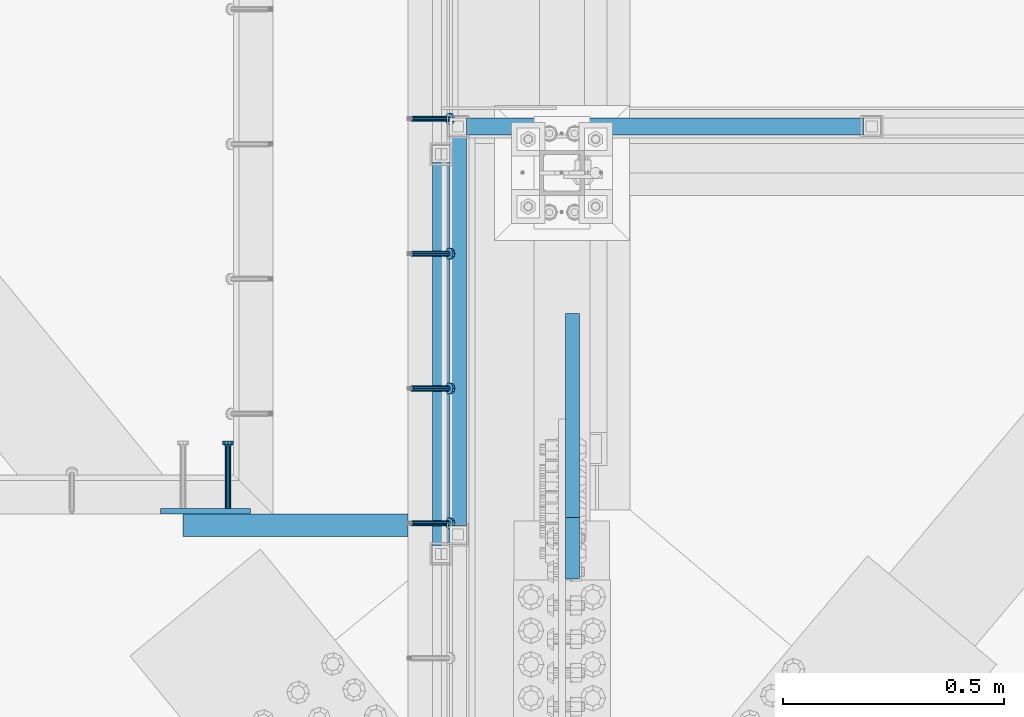
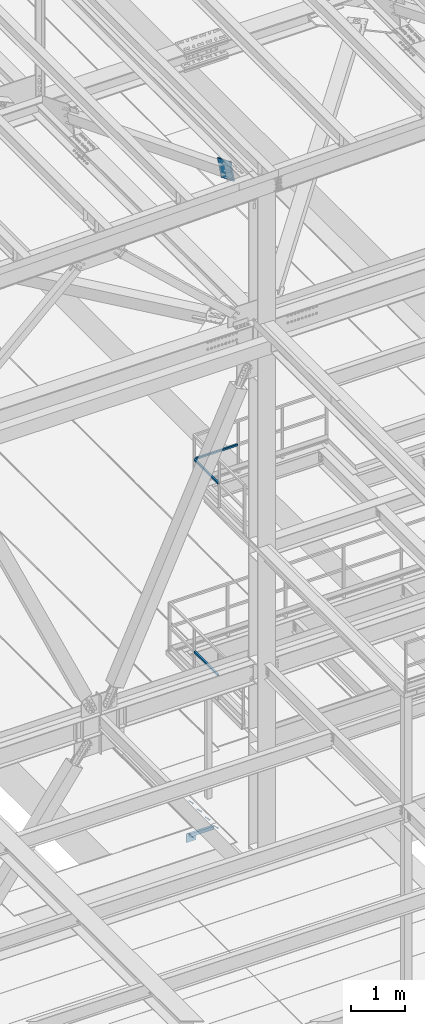
# One storey, part 2111 of 3843: 6 beams, 5 members, 6 elements without a shape of their own.
"""IFC2X3 building model written with IfcOpenShell, lengths in millimetres."""

from ifc_helpers import new_model, si_unit, frame, origin_with_axes, place, context, subcontext, project, spatial, faceted_brep, material, type_object, element, aggregate, save


model = new_model("IFC2X3")

# Units and contexts
model_context = context("Model", 3, precision=1e-05, world=origin_with_axes())
body_context = subcontext(model_context, "Body", "Model", "MODEL_VIEW")
ifc_project = project(units=[si_unit("LENGTHUNIT", "METRE", prefix="MILLI"), si_unit("AREAUNIT", "SQUARE_METRE"), si_unit("VOLUMEUNIT", "CUBIC_METRE"), si_unit("MASSUNIT", "GRAM", prefix="KILO"), si_unit("TIMEUNIT", "SECOND"), si_unit("PLANEANGLEUNIT", "RADIAN"), si_unit("SOLIDANGLEUNIT", "STERADIAN"), si_unit("THERMODYNAMICTEMPERATUREUNIT", "DEGREE_CELSIUS"), si_unit("LUMINOUSINTENSITYUNIT", "LUMEN")], contexts=[model_context])

# Site, building, storey
site_placement = place(None, origin_with_axes())
site = spatial("IfcSite", under=ifc_project, at=site_placement, CompositionType="ELEMENT")
building_placement = place(site_placement, origin_with_axes())
building = spatial("IfcBuilding", under=site, at=building_placement, Name="Undefined", CompositionType="ELEMENT")
storey_placement = place(building_placement, origin_with_axes())
storey = spatial("IfcBuildingStorey", under=building, at=storey_placement, Name="Undefined", CompositionType="ELEMENT", Elevation=0.0)

# Assembly, members
assembly_1_placement = place(storey_placement, origin_with_axes())
assembly_1 = element("IfcElementAssembly", 1, at=assembly_1_placement, inside=storey, Name="EMBED_ANGLE", AssemblyPlace="NOTDEFINED", PredefinedType="RIGID_FRAME")
ifc_material_1 = material(Name="STEEL/A108")
member_type_1 = type_object("IfcMemberType", PredefinedType="NOTDEFINED")
member_1_placement = place(assembly_1_placement, frame((48656.0495, 27719.3375, 30446.6625), z_axis=(0.0, 1.0, 0.0), x_axis=(0.707106781186548, 0.0, -0.707106781186548)))
member_1 = element("IfcMember", 2, at=member_1_placement, type_object=member_type_1, material=ifc_material_1, Name="HEADED STUD ANCHOR", context=body_context, shape_type="Brep", body=[
    faceted_brep([(7.27595761418343e-12, -3.18000006675175, 5.5), (0.0, -5.49999999998363, 3.1800000667572), (118.110000000976, -5.49999999999091, 3.1800000667572), (118.110000000983, -3.18000006675175, 5.5), (0.0, -6.3499999046162, 0.0), (118.110000000968, -6.34999990461256, 0.0), (0.0, -5.49999999998363, -3.1800000667572), (118.110000000976, -5.49999999999091, -3.1800000667572), (7.27595761418343e-12, -3.18000006675175, -5.5), (118.110000000983, -3.18000006675175, -5.5), (7.27595761418343e-12, -1.81898940354586e-12, -6.34999990463257), (118.110000000968, -1.81898940354586e-12, -6.34999990463257), (0.0, 3.18000006675175, -5.5), (118.110000000968, 3.18000006674811, -5.5), (7.27595761418343e-12, 5.49999999998363, -3.1800000667572), (118.110000000983, 5.49999999998363, -3.1800000667572), (7.27595761418343e-12, 6.3499999046162, 0.0), (118.110000000976, 6.34999990461256, 0.0), (7.27595761418343e-12, 5.49999999998363, 3.1800000667572), (118.110000000983, 5.49999999998363, 3.1800000667572), (0.0, 3.18000006675175, 5.5), (118.110000000968, 3.18000006674811, 5.5), (7.27595761418343e-12, -1.81898940354586e-12, 6.34999990463257), (118.110000000968, -1.81898940354586e-12, 6.34999990463257), (120.650000000991, -10.9899997710909, 6.34999990463257), (120.650000000998, -6.34000015257152, 10.9899997711182), (120.650000000991, -12.6999998092379, 0.0), (120.650000000991, -10.9899997710909, -6.34999990463257), (120.650000000998, -6.34000015257152, -10.9899997711182), (120.650000000991, -1.81898940354586e-12, -12.6899995803833), (120.650000000991, 6.34000015257152, -10.9899997711182), (120.650000000998, 10.9899997710909, -6.34999990463257), (120.650000000991, 12.6999998092342, 0.0), (120.650000000998, 10.9899997710909, 6.34999990463257), (120.650000000991, 6.34000015257152, 10.9899997711182), (120.650000000991, -1.81898940354586e-12, 12.6899995803833), (127.000000001048, -10.9899997710945, 6.34999990463257), (127.000000001048, -6.34000015257152, 10.9899997711182), (127.000000001048, -12.6999998092342, 0.0), (127.000000001048, -10.9899997710945, -6.34999990463257), (127.000000001048, -6.34000015257152, -10.9899997711182), (127.000000001048, 1.81898940354586e-12, -12.6899995803833), (127.000000001048, 6.34000015256788, -10.9899997711182), (127.000000001048, 10.9899997710909, -6.34999990463257), (127.000000001048, 12.6999998092379, 0.0), (127.000000001048, 10.9899997710909, 6.34999990463257), (127.000000001048, 6.34000015256788, 10.9899997711182), (127.000000001048, 1.81898940354586e-12, 12.6899995803833)], [[[0, 1, 2, 3]], [[1, 4, 5, 2]], [[4, 6, 7, 5]], [[6, 8, 9, 7]], [[8, 10, 11, 9]], [[10, 12, 13, 11]], [[12, 14, 15, 13]], [[14, 16, 17, 15]], [[16, 18, 19, 17]], [[18, 20, 21, 19]], [[20, 22, 23, 21]], [[22, 0, 3, 23]], [[22, 20, 18, 16, 14, 12, 10, 8, 6, 4, 1, 0]], [[3, 2, 24, 25]], [[2, 5, 26, 24]], [[5, 7, 27, 26]], [[7, 9, 28, 27]], [[9, 11, 29, 28]], [[11, 13, 30, 29]], [[13, 15, 31, 30]], [[15, 17, 32, 31]], [[17, 19, 33, 32]], [[19, 21, 34, 33]], [[21, 23, 35, 34]], [[23, 3, 25, 35]], [[25, 24, 36, 37]], [[24, 26, 38, 36]], [[26, 27, 39, 38]], [[27, 28, 40, 39]], [[28, 29, 41, 40]], [[29, 30, 42, 41]], [[30, 31, 43, 42]], [[31, 32, 44, 43]], [[32, 33, 45, 44]], [[33, 34, 46, 45]], [[34, 35, 47, 46]], [[35, 25, 37, 47]], [[38, 39, 40, 41, 42, 43, 44, 45, 46, 47, 37, 36]]]),
])
member_2_placement = place(assembly_1_placement, frame((48656.0495, 27414.5375, 30446.6625), z_axis=(0.0, 1.0, 0.0), x_axis=(0.707106781186548, 0.0, -0.707106781186548)))
member_2 = element("IfcMember", 3, at=member_2_placement, type_object=member_type_1, material=ifc_material_1, Name="HEADED STUD ANCHOR", context=body_context, shape_type="Brep", body=[
    faceted_brep([(7.27595761418343e-12, -3.18000006675175, 5.5), (0.0, -5.49999999998363, 3.1800000667572), (118.110000000976, -5.49999999999091, 3.1800000667572), (118.110000000983, -3.18000006675175, 5.5), (0.0, -6.3499999046162, 0.0), (118.110000000968, -6.34999990461256, 0.0), (0.0, -5.49999999998363, -3.1800000667572), (118.110000000976, -5.49999999999091, -3.1800000667572), (7.27595761418343e-12, -3.18000006675175, -5.5), (118.110000000983, -3.18000006675175, -5.5), (7.27595761418343e-12, -1.81898940354586e-12, -6.34999990463257), (118.110000000968, -1.81898940354586e-12, -6.34999990463257), (0.0, 3.18000006675175, -5.5), (118.110000000968, 3.18000006674811, -5.5), (7.27595761418343e-12, 5.49999999998363, -3.1800000667572), (118.110000000983, 5.49999999998363, -3.1800000667572), (7.27595761418343e-12, 6.3499999046162, 0.0), (118.110000000976, 6.34999990461256, 0.0), (7.27595761418343e-12, 5.49999999998363, 3.1800000667572), (118.110000000983, 5.49999999998363, 3.1800000667572), (0.0, 3.18000006675175, 5.5), (118.110000000968, 3.18000006674811, 5.5), (7.27595761418343e-12, -1.81898940354586e-12, 6.34999990463257), (118.110000000968, -1.81898940354586e-12, 6.34999990463257), (120.650000000991, -10.9899997710909, 6.34999990463257), (120.650000000998, -6.34000015257152, 10.9899997711182), (120.650000000991, -12.6999998092379, 0.0), (120.650000000991, -10.9899997710909, -6.34999990463257), (120.650000000998, -6.34000015257152, -10.9899997711182), (120.650000000991, -1.81898940354586e-12, -12.6899995803833), (120.650000000991, 6.34000015257152, -10.9899997711182), (120.650000000998, 10.9899997710909, -6.34999990463257), (120.650000000991, 12.6999998092342, 0.0), (120.650000000998, 10.9899997710909, 6.34999990463257), (120.650000000991, 6.34000015257152, 10.9899997711182), (120.650000000991, -1.81898940354586e-12, 12.6899995803833), (127.000000001048, -10.9899997710945, 6.34999990463257), (127.000000001048, -6.34000015257152, 10.9899997711182), (127.000000001048, -12.6999998092342, 0.0), (127.000000001048, -10.9899997710945, -6.34999990463257), (127.000000001048, -6.34000015257152, -10.9899997711182), (127.000000001048, 1.81898940354586e-12, -12.6899995803833), (127.000000001048, 6.34000015256788, -10.9899997711182), (127.000000001048, 10.9899997710909, -6.34999990463257), (127.000000001048, 12.6999998092379, 0.0), (127.000000001048, 10.9899997710909, 6.34999990463257), (127.000000001048, 6.34000015256788, 10.9899997711182), (127.000000001048, 1.81898940354586e-12, 12.6899995803833)], [[[0, 1, 2, 3]], [[1, 4, 5, 2]], [[4, 6, 7, 5]], [[6, 8, 9, 7]], [[8, 10, 11, 9]], [[10, 12, 13, 11]], [[12, 14, 15, 13]], [[14, 16, 17, 15]], [[16, 18, 19, 17]], [[18, 20, 21, 19]], [[20, 22, 23, 21]], [[22, 0, 3, 23]], [[22, 20, 18, 16, 14, 12, 10, 8, 6, 4, 1, 0]], [[3, 2, 24, 25]], [[2, 5, 26, 24]], [[5, 7, 27, 26]], [[7, 9, 28, 27]], [[9, 11, 29, 28]], [[11, 13, 30, 29]], [[13, 15, 31, 30]], [[15, 17, 32, 31]], [[17, 19, 33, 32]], [[19, 21, 34, 33]], [[21, 23, 35, 34]], [[23, 3, 25, 35]], [[25, 24, 36, 37]], [[24, 26, 38, 36]], [[26, 27, 39, 38]], [[27, 28, 40, 39]], [[28, 29, 41, 40]], [[29, 30, 42, 41]], [[30, 31, 43, 42]], [[31, 32, 44, 43]], [[32, 33, 45, 44]], [[33, 34, 46, 45]], [[34, 35, 47, 46]], [[35, 25, 37, 47]], [[38, 39, 40, 41, 42, 43, 44, 45, 46, 47, 37, 36]]]),
])
member_3_placement = place(assembly_1_placement, frame((48656.0495, 27109.7375, 30446.6625), z_axis=(0.0, 1.0, 0.0), x_axis=(0.707106781186548, 0.0, -0.707106781186548)))
member_3 = element("IfcMember", 4, at=member_3_placement, type_object=member_type_1, material=ifc_material_1, Name="HEADED STUD ANCHOR", context=body_context, shape_type="Brep", body=[
    faceted_brep([(7.27595761418343e-12, -3.18000006675175, 5.5), (0.0, -5.49999999998363, 3.1800000667572), (118.110000000976, -5.49999999999091, 3.1800000667572), (118.110000000983, -3.18000006675175, 5.5), (0.0, -6.3499999046162, 0.0), (118.110000000968, -6.34999990461256, 0.0), (0.0, -5.49999999998363, -3.1800000667572), (118.110000000976, -5.49999999999091, -3.1800000667572), (7.27595761418343e-12, -3.18000006675175, -5.5), (118.110000000983, -3.18000006675175, -5.5), (7.27595761418343e-12, -1.81898940354586e-12, -6.34999990463257), (118.110000000968, -1.81898940354586e-12, -6.34999990463257), (0.0, 3.18000006675175, -5.5), (118.110000000968, 3.18000006674811, -5.5), (7.27595761418343e-12, 5.49999999998363, -3.1800000667572), (118.110000000983, 5.49999999998363, -3.1800000667572), (7.27595761418343e-12, 6.3499999046162, 0.0), (118.110000000976, 6.34999990461256, 0.0), (7.27595761418343e-12, 5.49999999998363, 3.1800000667572), (118.110000000983, 5.49999999998363, 3.1800000667572), (0.0, 3.18000006675175, 5.5), (118.110000000968, 3.18000006674811, 5.5), (7.27595761418343e-12, -1.81898940354586e-12, 6.34999990463257), (118.110000000968, -1.81898940354586e-12, 6.34999990463257), (120.650000000991, -10.9899997710909, 6.34999990463257), (120.650000000998, -6.34000015257152, 10.9899997711182), (120.650000000991, -12.6999998092379, 0.0), (120.650000000991, -10.9899997710909, -6.34999990463257), (120.650000000998, -6.34000015257152, -10.9899997711182), (120.650000000991, -1.81898940354586e-12, -12.6899995803833), (120.650000000991, 6.34000015257152, -10.9899997711182), (120.650000000998, 10.9899997710909, -6.34999990463257), (120.650000000991, 12.6999998092342, 0.0), (120.650000000998, 10.9899997710909, 6.34999990463257), (120.650000000991, 6.34000015257152, 10.9899997711182), (120.650000000991, -1.81898940354586e-12, 12.6899995803833), (127.000000001048, -10.9899997710945, 6.34999990463257), (127.000000001048, -6.34000015257152, 10.9899997711182), (127.000000001048, -12.6999998092342, 0.0), (127.000000001048, -10.9899997710945, -6.34999990463257), (127.000000001048, -6.34000015257152, -10.9899997711182), (127.000000001048, 1.81898940354586e-12, -12.6899995803833), (127.000000001048, 6.34000015256788, -10.9899997711182), (127.000000001048, 10.9899997710909, -6.34999990463257), (127.000000001048, 12.6999998092379, 0.0), (127.000000001048, 10.9899997710909, 6.34999990463257), (127.000000001048, 6.34000015256788, 10.9899997711182), (127.000000001048, 1.81898940354586e-12, 12.6899995803833)], [[[0, 1, 2, 3]], [[1, 4, 5, 2]], [[4, 6, 7, 5]], [[6, 8, 9, 7]], [[8, 10, 11, 9]], [[10, 12, 13, 11]], [[12, 14, 15, 13]], [[14, 16, 17, 15]], [[16, 18, 19, 17]], [[18, 20, 21, 19]], [[20, 22, 23, 21]], [[22, 0, 3, 23]], [[22, 20, 18, 16, 14, 12, 10, 8, 6, 4, 1, 0]], [[3, 2, 24, 25]], [[2, 5, 26, 24]], [[5, 7, 27, 26]], [[7, 9, 28, 27]], [[9, 11, 29, 28]], [[11, 13, 30, 29]], [[13, 15, 31, 30]], [[15, 17, 32, 31]], [[17, 19, 33, 32]], [[19, 21, 34, 33]], [[21, 23, 35, 34]], [[23, 3, 25, 35]], [[25, 24, 36, 37]], [[24, 26, 38, 36]], [[26, 27, 39, 38]], [[27, 28, 40, 39]], [[28, 29, 41, 40]], [[29, 30, 42, 41]], [[30, 31, 43, 42]], [[31, 32, 44, 43]], [[32, 33, 45, 44]], [[33, 34, 46, 45]], [[34, 35, 47, 46]], [[35, 25, 37, 47]], [[38, 39, 40, 41, 42, 43, 44, 45, 46, 47, 37, 36]]]),
])
member_4_placement = place(assembly_1_placement, frame((48656.0495, 26804.9375, 30446.6625), z_axis=(0.0, 1.0, 0.0), x_axis=(0.707106781186548, 0.0, -0.707106781186548)))
member_4 = element("IfcMember", 5, at=member_4_placement, type_object=member_type_1, material=ifc_material_1, Name="HEADED STUD ANCHOR", context=body_context, shape_type="Brep", body=[
    faceted_brep([(7.27595761418343e-12, -3.18000006675175, 5.5), (0.0, -5.49999999998363, 3.1800000667572), (118.110000000976, -5.49999999999091, 3.1800000667572), (118.110000000983, -3.18000006675175, 5.5), (0.0, -6.3499999046162, 0.0), (118.110000000968, -6.34999990461256, 0.0), (0.0, -5.49999999998363, -3.1800000667572), (118.110000000976, -5.49999999999091, -3.1800000667572), (7.27595761418343e-12, -3.18000006675175, -5.5), (118.110000000983, -3.18000006675175, -5.5), (7.27595761418343e-12, -1.81898940354586e-12, -6.34999990463257), (118.110000000968, -1.81898940354586e-12, -6.34999990463257), (0.0, 3.18000006675175, -5.5), (118.110000000968, 3.18000006674811, -5.5), (7.27595761418343e-12, 5.49999999998363, -3.1800000667572), (118.110000000983, 5.49999999998363, -3.1800000667572), (7.27595761418343e-12, 6.3499999046162, 0.0), (118.110000000976, 6.34999990461256, 0.0), (7.27595761418343e-12, 5.49999999998363, 3.1800000667572), (118.110000000983, 5.49999999998363, 3.1800000667572), (0.0, 3.18000006675175, 5.5), (118.110000000968, 3.18000006674811, 5.5), (7.27595761418343e-12, -1.81898940354586e-12, 6.34999990463257), (118.110000000968, -1.81898940354586e-12, 6.34999990463257), (120.650000000991, -10.9899997710909, 6.34999990463257), (120.650000000998, -6.34000015257152, 10.9899997711182), (120.650000000991, -12.6999998092379, 0.0), (120.650000000991, -10.9899997710909, -6.34999990463257), (120.650000000998, -6.34000015257152, -10.9899997711182), (120.650000000991, -1.81898940354586e-12, -12.6899995803833), (120.650000000991, 6.34000015257152, -10.9899997711182), (120.650000000998, 10.9899997710909, -6.34999990463257), (120.650000000991, 12.6999998092342, 0.0), (120.650000000998, 10.9899997710909, 6.34999990463257), (120.650000000991, 6.34000015257152, 10.9899997711182), (120.650000000991, -1.81898940354586e-12, 12.6899995803833), (127.000000001048, -10.9899997710945, 6.34999990463257), (127.000000001048, -6.34000015257152, 10.9899997711182), (127.000000001048, -12.6999998092342, 0.0), (127.000000001048, -10.9899997710945, -6.34999990463257), (127.000000001048, -6.34000015257152, -10.9899997711182), (127.000000001048, 1.81898940354586e-12, -12.6899995803833), (127.000000001048, 6.34000015256788, -10.9899997711182), (127.000000001048, 10.9899997710909, -6.34999990463257), (127.000000001048, 12.6999998092379, 0.0), (127.000000001048, 10.9899997710909, 6.34999990463257), (127.000000001048, 6.34000015256788, 10.9899997711182), (127.000000001048, 1.81898940354586e-12, 12.6899995803833)], [[[0, 1, 2, 3]], [[1, 4, 5, 2]], [[4, 6, 7, 5]], [[6, 8, 9, 7]], [[8, 10, 11, 9]], [[10, 12, 13, 11]], [[12, 14, 15, 13]], [[14, 16, 17, 15]], [[16, 18, 19, 17]], [[18, 20, 21, 19]], [[20, 22, 23, 21]], [[22, 0, 3, 23]], [[22, 20, 18, 16, 14, 12, 10, 8, 6, 4, 1, 0]], [[3, 2, 24, 25]], [[2, 5, 26, 24]], [[5, 7, 27, 26]], [[7, 9, 28, 27]], [[9, 11, 29, 28]], [[11, 13, 30, 29]], [[13, 15, 31, 30]], [[15, 17, 32, 31]], [[17, 19, 33, 32]], [[19, 21, 34, 33]], [[21, 23, 35, 34]], [[23, 3, 25, 35]], [[25, 24, 36, 37]], [[24, 26, 38, 36]], [[26, 27, 39, 38]], [[27, 28, 40, 39]], [[28, 29, 41, 40]], [[29, 30, 42, 41]], [[30, 31, 43, 42]], [[31, 32, 44, 43]], [[32, 33, 45, 44]], [[33, 34, 46, 45]], [[34, 35, 47, 46]], [[35, 25, 37, 47]], [[38, 39, 40, 41, 42, 43, 44, 45, 46, 47, 37, 36]]]),
])
aggregate(assembly_1, [member_1, member_2, member_3, member_4])

# Assembly, beams
assembly_2_placement = place(storey_placement, origin_with_axes())
assembly_2 = element("IfcElementAssembly", 6, at=assembly_2_placement, inside=storey, Name="RAIL", AssemblyPlace="NOTDEFINED", PredefinedType="RIGID_FRAME")
ifc_material_2 = material()
beam_type_1 = type_object("IfcBeamType", Name="HSS1-1/2X1-1/2X1/4", PredefinedType="NOTDEFINED")
beam_1_placement = place(assembly_2_placement, frame((49697.2166595459, 27701.8747862042, 38099.9999983618), z_axis=(0.0, 0.0, 1.0), x_axis=(-1.0, 0.0, 0.0)))
beam_1 = element("IfcBeam", 7, at=beam_1_placement, type_object=beam_type_1, material=ifc_material_2, Name="RAIL", ObjectType="HSS1-1/2X1-1/2X1/4", context=body_context, shape_type="Brep", body=[
    faceted_brep([(916.516671752906, -19.0500000000029, 19.0499992350015), (916.516671752906, -19.0499992350015, -19.0499992350015), (916.516671752906, 19.0499992350015, -19.0499992350015), (916.516671752906, 19.0499992350015, 19.0499992350015), (916.516671752906, -12.6999993300014, 12.6999993299978), (916.516671752906, 12.6999993300014, 12.6999993299978), (916.516671752906, 12.6999993300014, -12.6999993299978), (916.516671752906, -12.6999993300014, -12.6999993299978), (19.0499992350015, 19.0499992350015, 19.0499992350015), (19.0499992350015, -19.0499992350015, 19.0499992350015), (19.0499992350015, -19.0499992350015, -19.0499992350015), (19.0499992350015, 19.0499992350015, -19.0499992350015), (19.0499992350015, 12.6999993299978, 12.6999993299978), (19.0499992350015, -12.6999993299978, 12.6999993299978), (19.0499992350015, -12.6999993299978, -12.6999993299978), (19.0499992350015, 12.6999993299978, -12.6999993299978)], [[[0, 1, 2, 3], [4, 5, 6, 7]], [[8, 9, 0, 3]], [[10, 11, 2, 1]], [[9, 10, 1, 0]], [[11, 8, 3, 2]], [[10, 9, 8, 11], [12, 13, 14, 15]], [[14, 13, 4, 7]], [[15, 14, 7, 6]], [[12, 15, 6, 5]], [[13, 12, 5, 4]]]),
])
beam_2_placement = place(assembly_2_placement, frame((48761.6499877927, 27701.8747862042, 38099.9999983618), z_axis=(0.0, 0.0, 1.0), x_axis=(0.0, -1.0, 0.0)))
beam_2 = element("IfcBeam", 8, at=beam_2_placement, type_object=beam_type_1, material=ifc_material_2, Name="RAIL", ObjectType="HSS1-1/2X1-1/2X1/4", context=body_context, shape_type="Brep", body=[
    faceted_brep([(903.287393102968, -19.0500000001557, 19.0499992350015), (903.287393102968, -19.0499992350015, -19.0499992350015), (903.287393102968, 19.0499992350015, -19.0499992350015), (903.287393102968, 19.0499992350015, 19.0499992350015), (903.287393102968, -12.6999993299978, 12.6999993299978), (903.287393102968, 12.6999993299978, 12.6999993299978), (903.287393102968, 12.6999993299978, -12.6999993299978), (903.287393102968, -12.6999993299978, -12.6999993299978), (19.0499992350015, 19.0499992350015, -19.0499992350015), (19.0499992350015, 19.0499992350015, 19.0499992350015), (19.0499992350015, -19.0499992350015, 19.0499992350015), (19.0499992350015, -19.0499992350015, -19.0499992350015), (19.0499992350015, 12.6999993299978, 12.6999993299978), (19.0499992350015, -12.6999993299978, 12.6999993299978), (19.0499992350015, -12.6999993299978, -12.6999993299978), (19.0499992350015, 12.6999993299978, -12.6999993299978)], [[[0, 1, 2, 3], [4, 5, 6, 7]], [[8, 9, 3, 2]], [[9, 10, 0, 3]], [[10, 11, 1, 0]], [[11, 8, 2, 1]], [[11, 10, 9, 8], [12, 13, 14, 15]], [[14, 13, 4, 7]], [[15, 14, 7, 6]], [[12, 15, 6, 5]], [[13, 12, 5, 4]]]),
])
aggregate(assembly_2, [beam_1, beam_2])

# Assembly, beam
assembly_3_placement = place(storey_placement, origin_with_axes())
assembly_3 = element("IfcElementAssembly", 9, at=assembly_3_placement, inside=storey, Name="RAIL", AssemblyPlace="NOTDEFINED", PredefinedType="RIGID_FRAME")
beam_3_placement = place(assembly_3_placement, frame((48723.549999976, 27639.4333333334, 33832.8000002631), z_axis=(0.0, 0.0, 1.0), x_axis=(0.0, -1.0, 0.0)))
beam_3 = element("IfcBeam", 10, at=beam_3_placement, type_object=beam_type_1, material=ifc_material_2, Name="RAIL", ObjectType="HSS1-1/2X1-1/2X1/4", context=body_context, shape_type="Brep", body=[
    faceted_brep([(19.0499992350015, 12.6999993299978, -12.6999993299978), (19.0499992350015, -12.6999993299978, -12.6999993299978), (884.766667431661, -12.6999993299978, -12.6999993299978), (884.766667431661, 12.6999993299978, -12.6999993299978), (19.0499992350015, -12.6999993299978, 12.6999993299978), (884.766667431661, -12.6999993299978, 12.6999993299978), (19.0499992350015, 12.6999993299978, 12.6999993299978), (884.766667431661, 12.6999993299978, 12.6999993299978), (19.0499992350015, 19.0499992350015, -19.0499992350015), (19.0499992350015, 19.0499992350015, 19.0499992350015), (884.766667431661, 19.0499992350015, 19.0499992350015), (884.766667431661, 19.0499992350015, -19.0499992350015), (19.0499992350015, -19.0499992350015, 19.0499992350015), (884.766667431661, -19.0499992350015, 19.0499992350015), (19.0499992350015, -19.0499992350015, -19.0499992350015), (884.766667431661, -19.0499992350015, -19.0499992350015)], [[[0, 1, 2, 3]], [[1, 4, 5, 2]], [[4, 6, 7, 5]], [[6, 0, 3, 7]], [[8, 9, 10, 11]], [[9, 12, 13, 10]], [[12, 14, 15, 13]], [[14, 8, 11, 15]], [[13, 15, 11, 10], [5, 7, 3, 2]], [[14, 12, 9, 8], [6, 4, 1, 0]]]),
])
aggregate(assembly_3, [beam_3])

assembly_4_placement = place(storey_placement, origin_with_axes())
assembly_4 = element("IfcElementAssembly", 11, at=assembly_4_placement, inside=storey, Name="EMBED PLATE", AssemblyPlace="NOTDEFINED", PredefinedType="RIGID_FRAME")
ifc_material_3 = material(Name="STEEL/A36")
beam_type_2 = type_object("IfcBeamType", PredefinedType="NOTDEFINED")
beam_4_placement = place(assembly_4_placement, frame((48190.911942391, 26831.9260728433, 30445.075), z_axis=(1.0, 0.0, 0.0), x_axis=(0.0, 0.0, -1.0)))
beam_4 = element("IfcBeam", 12, at=beam_4_placement, type_object=beam_type_2, material=ifc_material_3, Name="EMBED PLATE", context=body_context, shape_type="Brep", body=[
    faceted_brep([(1.74622982740402e-10, 6.35000000000582, -101.600000000195), (-1.67347025126219e-10, 6.35000000000582, 101.600000000151), (203.200000000001, 6.35000000000582, 101.599999999999), (203.200000000001, 6.35000000000582, -101.599999999999), (-1.67347025126219e-10, -6.35000000000582, 101.600000000151), (203.200000000001, -6.35000000000582, 101.599999999999), (1.74622982740402e-10, -6.35000000000582, -101.600000000195), (203.200000000001, -6.35000000000582, -101.599999999999)], [[[0, 1, 2, 3]], [[1, 4, 5, 2]], [[4, 6, 7, 5]], [[6, 0, 3, 7]], [[5, 7, 3, 2]], [[6, 4, 1, 0]]]),
])

# Assembly, member
assembly_5_placement = place(storey_placement, origin_with_axes())
assembly_5 = element("IfcElementAssembly", 13, at=assembly_5_placement, inside=storey, AssemblyPlace="NOTDEFINED", PredefinedType="RIGID_FRAME")
ifc_material_4 = material(Name="STEEL/A572-50")
member_type_2 = type_object("IfcMemberType", PredefinedType="NOTDEFINED")
member_5_placement = place(assembly_5_placement, frame((49020.4125, 26748.42846793, 45044.6906264161), z_axis=(0.0, -0.366107655820124, -0.930572503542789), x_axis=(0.0, 0.930572503542787, -0.366107655820128)))
member_5 = element("IfcMember", 14, at=member_5_placement, type_object=member_type_2, material=ifc_material_4, Name="PLATE", context=body_context, shape_type="Brep", body=[
    faceted_brep([(3.56521923094988e-10, 15.875, -190.500000000146), (-3.61978891305625e-10, 15.875, 190.500000000153), (495.299999995012, 15.875, 190.500000001084), (495.299999995726, 15.875, -190.499999999221), (-3.61978891305625e-10, -15.875, 190.500000000153), (495.299999995012, -15.875, 190.500000001084), (3.56521923094988e-10, -15.875, -190.500000000146), (495.299999995726, -15.875, -190.499999999221)], [[[0, 1, 2, 3]], [[1, 4, 5, 2]], [[4, 6, 7, 5]], [[6, 0, 3, 7]], [[5, 7, 3, 2]], [[6, 4, 1, 0]]]),
])
aggregate(assembly_5, [member_5])

# Beam
beam_type_3 = type_object("IfcBeamType", PredefinedType="NOTDEFINED")
beam_5_placement = place(assembly_4_placement, frame((48241.711942391, 26838.2760728433, 30292.675), z_axis=(-1.0, 0.0, 0.0), x_axis=(0.0, 1.0, 0.0)))
beam_5 = element("IfcBeam", 15, at=beam_5_placement, type_object=beam_type_3, material=ifc_material_1, Name="HEADED STUD ANCHOR", context=body_context, shape_type="Brep", body=[
    faceted_brep([(7.27595761418343e-12, -3.18000006675175, 5.5), (0.0, -5.49999999998363, 3.1800000667572), (141.731999999989, -5.5, 3.1800000667572), (141.731999999989, -3.1800000667572, 5.5), (0.0, -6.3499999046162, 0.0), (141.731999999989, -6.34999990463257, 0.0), (0.0, -5.49999999998363, -3.1800000667572), (141.731999999989, -5.5, -3.1800000667572), (7.27595761418343e-12, -3.18000006675175, -5.5), (141.731999999989, -3.1800000667572, -5.5), (7.27595761418343e-12, -1.81898940354586e-12, -6.34999990463257), (141.731999999989, 0.0, -6.34999990463257), (0.0, 3.18000006675175, -5.5), (141.731999999989, 3.1800000667572, -5.5), (7.27595761418343e-12, 5.49999999998363, -3.1800000667572), (141.731999999989, 5.5, -3.1800000667572), (7.27595761418343e-12, 6.3499999046162, 0.0), (141.731999999989, 6.34999990463257, 0.0), (7.27595761418343e-12, 5.49999999998363, 3.1800000667572), (141.731999999989, 5.5, 3.1800000667572), (0.0, 3.18000006675175, 5.5), (141.731999999989, 3.1800000667572, 5.5), (7.27595761418343e-12, -1.81898940354586e-12, 6.34999990463257), (141.731999999989, 0.0, 6.34999990463257), (144.779999999999, -10.9899997711182, 6.34999990463257), (144.779999999999, -6.34000015258789, 10.9899997711182), (144.779999999999, -12.6999998092651, 0.0), (144.779999999999, -10.9899997711182, -6.34999990463257), (144.779999999999, -6.34000015258789, -10.9899997711182), (144.779999999999, 0.0, -12.6899995803833), (144.779999999999, 6.34000015258789, -10.9899997711182), (144.779999999999, 10.9899997711182, -6.34999990463257), (144.779999999999, 12.6999998092651, 0.0), (144.779999999999, 10.9899997711182, 6.34999990463257), (144.779999999999, 6.34000015258789, 10.9899997711182), (144.779999999999, 0.0, 12.6899995803833), (152.399999999994, -10.9899997711182, 6.34999990463257), (152.399999999994, -6.34000015258789, 10.9899997711182), (152.399999999994, -12.6999998092651, 0.0), (152.399999999994, -10.9899997711182, -6.34999990463257), (152.399999999994, -6.34000015258789, -10.9899997711182), (152.399999999994, 0.0, -12.6899995803833), (152.399999999994, 6.34000015258789, -10.9899997711182), (152.399999999994, 10.9899997711182, -6.34999990463257), (152.399999999994, 12.6999998092651, 0.0), (152.399999999994, 10.9899997711182, 6.34999990463257), (152.399999999994, 6.34000015258789, 10.9899997711182), (152.399999999994, 0.0, 12.6899995803833)], [[[0, 1, 2, 3]], [[1, 4, 5, 2]], [[4, 6, 7, 5]], [[6, 8, 9, 7]], [[8, 10, 11, 9]], [[10, 12, 13, 11]], [[12, 14, 15, 13]], [[14, 16, 17, 15]], [[16, 18, 19, 17]], [[18, 20, 21, 19]], [[20, 22, 23, 21]], [[22, 0, 3, 23]], [[22, 20, 18, 16, 14, 12, 10, 8, 6, 4, 1, 0]], [[3, 2, 24, 25]], [[2, 5, 26, 24]], [[5, 7, 27, 26]], [[7, 9, 28, 27]], [[9, 11, 29, 28]], [[11, 13, 30, 29]], [[13, 15, 31, 30]], [[15, 17, 32, 31]], [[17, 19, 33, 32]], [[19, 21, 34, 33]], [[21, 23, 35, 34]], [[23, 3, 25, 35]], [[25, 24, 36, 37]], [[24, 26, 38, 36]], [[26, 27, 39, 38]], [[27, 28, 40, 39]], [[28, 29, 41, 40]], [[29, 30, 42, 41]], [[30, 31, 43, 42]], [[31, 32, 44, 43]], [[32, 33, 45, 44]], [[33, 34, 46, 45]], [[34, 35, 47, 46]], [[35, 25, 37, 47]], [[38, 39, 40, 41, 42, 43, 44, 45, 46, 47, 37, 36]]]),
])

aggregate(assembly_4, [beam_5, beam_4])

# Assembly, beam
assembly_6_placement = place(storey_placement, origin_with_axes())
assembly_6 = element("IfcElementAssembly", 16, at=assembly_6_placement, inside=storey, Name="COVER PLATE", AssemblyPlace="NOTDEFINED", PredefinedType="RIGID_FRAME")
beam_type_4 = type_object("IfcBeamType", PredefinedType="NOTDEFINED")
beam_6_placement = place(assembly_6_placement, frame((48140.1118887463, 26800.1760728434, 30416.5), z_axis=(0.0, 0.0, 1.0), x_axis=(0.99999999999777, -2.11199999788599e-06, 0.0)))
beam_6 = element("IfcBeam", 17, at=beam_6_placement, type_object=beam_type_4, material=ifc_material_3, Name="COVER PLATE", context=body_context, shape_type="Brep", body=[
    faceted_brep([(0.0, 25.4000000000015, -38.0999999999985), (0.0, 25.4000000000015, 38.0999999999985), (508.000057618301, 25.4000000002234, 38.0999999999985), (508.000057618301, 25.4000000002234, -38.0999999999985), (0.0, -25.4000000000015, 38.0999999999985), (508.000057618337, -25.3999999997068, 38.0999999999985), (0.0, -25.4000000000015, -38.0999999999985), (508.000057618337, -25.3999999997068, -38.0999999999985)], [[[0, 1, 2, 3]], [[1, 4, 5, 2]], [[4, 6, 7, 5]], [[6, 0, 3, 7]], [[5, 7, 3, 2]], [[6, 4, 1, 0]]]),
])
aggregate(assembly_6, [beam_6])

save(model, "model.ifc")
